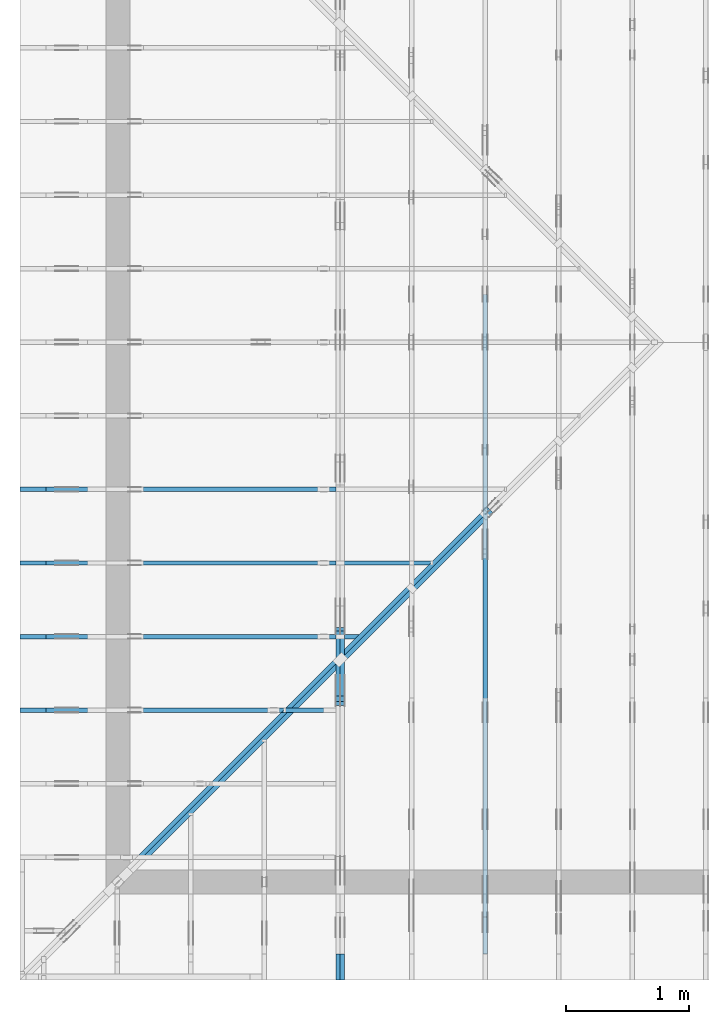
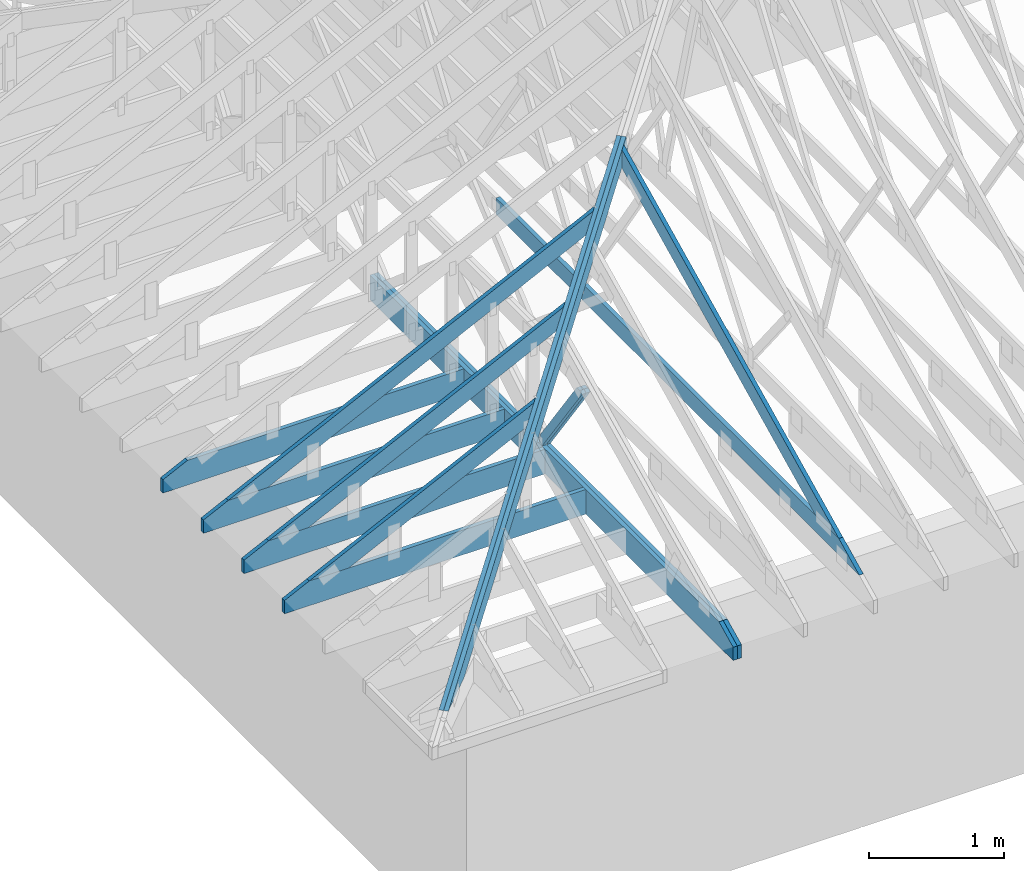
# One storey, part 3 of 159: 15 members, 7 elements without a shape of their own.
"""IFC2X3 building model written with IfcOpenShell, lengths in millimetres."""

from ifc_helpers import new_model, si_unit, frame, origin, origin_with_axes, origin_2d, place, context, project, spatial, faceted_brep, element, aggregate, save


model = new_model("IFC2X3")

# Units and contexts
model_context = context("Model", 3, precision=1e-05, world=origin())
plan_context = context("Plan", 2, precision=1e-05, world=origin_2d())
ifc_project = project(units=[si_unit("LENGTHUNIT", "METRE", prefix="MILLI"), si_unit("AREAUNIT", "SQUARE_METRE"), si_unit("VOLUMEUNIT", "CUBIC_METRE"), si_unit("SOLIDANGLEUNIT", "STERADIAN"), si_unit("PLANEANGLEUNIT", "RADIAN"), si_unit("MASSUNIT", "GRAM"), si_unit("TIMEUNIT", "SECOND"), si_unit("THERMODYNAMICTEMPERATUREUNIT", "DEGREE_CELSIUS"), si_unit("LUMINOUSINTENSITYUNIT", "LUMEN")], contexts=[model_context, plan_context])

# Site, building, storey
site_placement = place(None, origin_with_axes())
site = spatial("IfcSite", under=ifc_project, at=site_placement, CompositionType="ELEMENT")
building_placement = place(site_placement, origin_with_axes())
building = spatial("IfcBuilding", under=site, at=building_placement, Name="Plan 1", CompositionType="ELEMENT")
storey_placement = place(building_placement, origin_with_axes())
storey = spatial("IfcBuildingStorey", under=building, at=storey_placement, Name="Etasje 1", CompositionType="ELEMENT", Elevation=0.0)

# Assembly, member
assembly_1_placement = place(storey_placement, frame((-700.000000000007, 3282.0074014212605, 1.1021457184401395e-15), z_axis=(0.0, -1.0, 6.123031769111886e-17), x_axis=(1.0, 0.0, 0.0)))
assembly_1 = element("IfcElementAssembly", 1, at=assembly_1_placement, inside=storey, Name="S3 (19)", AssemblyPlace="FACTORY", PredefinedType="TRUSS")
member_1_placement = place(assembly_1_placement, frame((2575.022261404757, 223.00000000093104, -36.0), z_axis=(0.0, 0.0, 1.0), x_axis=(-1.0, 1.2246063538223773e-16, 0.0)))
member_1 = element("IfcMember", 2, at=member_1_placement, Name="S3-U11", context=model_context, shape_type="Brep", body=[
    faceted_brep([(2575.022261404768, 223.00000000093135, 36.0), (4.460788204596611e-05, 223.00000000093135, 36.0), (4.460788204596611e-05, 9.310383575211745e-10, 36.0), (2363.8409717319055, 9.310383575211745e-10, 36.0), (2575.022261404761, 103.00000000093135, 36.0), (4.460788204596611e-05, 223.00000000093135, 5.462709578404924e-21), (2575.022261404768, 223.00000000093135, 3.1533886225503453e-13), (2575.022261404761, 103.00000000093135, 3.1533886225503367e-13), (2363.8409717319055, 9.310383575211745e-10, 2.894774673408554e-13), (4.460788204596611e-05, 9.310383575211745e-10, 5.462709578404924e-21), (1.1401554882727804e-25, 9.310383575211745e-10, -6.981208276421509e-42), (2.2042914369942947e-15, 9.310383575211745e-10, 36.0), (2.9513013127233304e-14, 223.00000000093104, 36.0), (2.730872169035303e-14, 223.00000000093104, -1.6721217048386645e-30), (2363.8409657211496, 5.20089044280899e-13, -3.184521740898993e-29), (2363.8409657211496, 5.222933357177793e-13, 36.0), (8.67712118026388e-28, 9.310405618126114e-10, 36.0), (0.0, 9.310383575211745e-10, 0.0), (2575.022261404761, 103.00000000064097, -3.7865323450608567e-29), (2575.022261404761, 103.00000000064097, 36.0), (2363.8409657211496, 5.684341886080801e-13, 36.0), (2363.8409657211496, 5.684341886080801e-13, -2.524354896707238e-29), (2575.022261404755, 223.00000000093135, -7.825500179792437e-28), (2575.022261404755, 223.00000000093135, 36.0), (2575.022261404755, 103.00000000064031, 36.0), (2575.022261404755, 103.00000000064031, -3.534096855390133e-28), (0.0, 223.00000000093104, 0.0), (0.0, 223.00000000093104, 36.0), (2575.022261404768, 223.00000000093144, 36.0), (2575.022261404768, 223.00000000093146, 6.310887241768095e-30)], [[[0, 1, 2, 3, 4]], [[5, 6, 7, 8, 9]], [[10, 11, 12, 13]], [[14, 15, 16, 17]], [[18, 19, 20, 21]], [[22, 23, 24, 25]], [[26, 27, 28, 29]]]),
])
aggregate(assembly_1, [member_1])

# Assembly, members
assembly_2_placement = place(storey_placement, frame((-700.000000000007, 1482.0074014212605, 1.1021457184401395e-15), z_axis=(0.0, -1.0, 6.123031769111886e-17), x_axis=(1.0, 0.0, 0.0)))
assembly_2 = element("IfcElementAssembly", 3, at=assembly_2_placement, inside=storey, Name="S6 (18)", AssemblyPlace="FACTORY", PredefinedType="TRUSS")
member_2_placement = place(assembly_2_placement, frame((276.06014447168195, 89.97844131515879, -36.00000021758847), z_axis=(0.0, 0.0, 1.0), x_axis=(0.898794046299167, 0.4383711467890774, 0.0)))
member_2 = element("IfcMember", 4, at=member_2_placement, Name="S6-O53", context=model_context, shape_type="Brep", body=[
    faceted_brep([(2176.153074155777, 148.00000083082682, 2.253329398627102e-06), (2136.0994071584437, 147.9999951378918, 35.99999718737888), (2063.914983207369, 3.211827106497367e-07, 36.00000021758876), (2103.9686531498965, -1.7053025658242404e-13, 0.0), (4.108039797756646e-05, 148.00000032047896, 2.175884716848486e-07), (4.108039797756646e-05, 148.00000032047873, 36.00000021758847), (2136.099406314773, 148.0000003204786, 36.00000021758847), (2176.1530752906033, 148.00000032047882, 2.175884716848486e-07), (303.44505876091887, 3.208057108849971e-07, 2.1758847168484863e-07), (303.44505876091887, 3.208057108849971e-07, 36.00000021758847), (8.70477876020459e-05, 148.00000186174597, 36.00000021758847), (8.70477876020459e-05, 148.00000186174597, 2.1758847168484863e-07), (2103.9686530644794, 3.2119091710588915e-07, 2.175884716848486e-07), (2063.9149840886494, 3.211910385781581e-07, 36.00000021758847), (303.44509349416694, 3.211913619605502e-07, 36.00000021758847), (303.44509349416694, 3.2119124784577786e-07, 2.175884716848486e-07), (2136.099408561373, 148.00000032118282, 36.00000021758847), (0.00018828549389127147, 148.00000032118282, 36.00000021758847), (303.445012504244, 3.208056966741424e-07, 36.00000021758847), (2063.914983207369, 3.208056966741424e-07, 36.00000021758847), (0.0, 148.0000003209543, 2.1758847168484863e-07), (2176.153076171875, 148.0000003209543, 2.17588738177937e-07), (2103.968650817871, 3.2046978049038444e-07, 2.1758872933818643e-07), (303.4450683593751, 3.2046978049038444e-07, 2.1758850884492452e-07)], [[[0, 1, 2, 3]], [[4, 5, 6, 7]], [[8, 9, 10, 11]], [[12, 13, 14, 15]], [[16, 17, 18, 19]], [[20, 21, 22, 23]]]),
])
member_3_placement = place(assembly_2_placement, frame((2575.022261404756, 223.00000000093104, -36.0), z_axis=(0.0, 0.0, 1.0), x_axis=(-1.0, 1.2246063538223773e-16, 0.0)))
member_3 = element("IfcMember", 5, at=member_3_placement, Name="S6-U11", context=model_context, shape_type="Brep", body=[
    faceted_brep([(2575.022261404767, 223.00000000093135, 36.0), (4.4607881136471406e-05, 223.00000000093135, 36.0), (4.4607881136471406e-05, 9.310383575211745e-10, 36.0), (2363.8409717319046, 9.310383575211745e-10, 36.0), (2575.0222614047602, 103.00000000093135, 36.0), (4.4607881136471406e-05, 223.00000000093135, 5.462709467027625e-21), (2575.022261404767, 223.00000000093135, 3.1533886225503443e-13), (2575.0222614047602, 103.00000000093135, 3.1533886225503357e-13), (2363.8409717319046, 9.310383575211745e-10, 2.8947746734085526e-13), (4.4607881136471406e-05, 9.310383575211745e-10, 5.462709467027625e-21), (1.1401554882727804e-25, 9.310383575211745e-10, -6.981208276421509e-42), (2.2042914369942947e-15, 9.310383575211745e-10, 36.0), (2.9513013127233304e-14, 223.00000000093104, 36.0), (2.730872169035303e-14, 223.00000000093104, -1.6721217048386645e-30), (2363.8409657211487, 5.200890442812092e-13, -3.184521740901289e-29), (2363.8409657211487, 5.222933357180895e-13, 36.0), (8.67712118026388e-28, 9.310405618126114e-10, 36.0), (0.0, 9.310383575211745e-10, 0.0), (2575.0222614047602, 103.00000000064097, -5.048709793414476e-29), (2575.0222614047602, 103.00000000064097, 36.0), (2363.840965721148, 4.547473508864641e-13, 36.0), (2363.840965721148, 4.547473508864641e-13, -3.7865323450608567e-29), (2575.0222614047543, 223.00000000093135, -7.825500179792437e-28), (2575.0222614047543, 223.00000000093135, 36.0), (2575.0222614047543, 103.00000000064031, 36.0), (2575.0222614047543, 103.00000000064031, -3.534096855390133e-28), (0.0, 223.00000000093104, 0.0), (0.0, 223.00000000093104, 36.0), (2575.022261404767, 223.00000000093144, 36.0), (2575.022261404767, 223.00000000093146, 6.310887241768095e-30)], [[[0, 1, 2, 3, 4]], [[5, 6, 7, 8, 9]], [[10, 11, 12, 13]], [[14, 15, 16, 17]], [[18, 19, 20, 21]], [[22, 23, 24, 25]], [[26, 27, 28, 29]]]),
])
aggregate(assembly_2, [member_2, member_3])

assembly_3_placement = place(storey_placement, frame((-700.000000000007, 2682.0074014212605, 1.1021457184401395e-15), z_axis=(0.0, -1.0, 6.123031769111886e-17), x_axis=(1.0, 0.0, 0.0)))
assembly_3 = element("IfcElementAssembly", 6, at=assembly_3_placement, inside=storey, Name="S4 (17)", AssemblyPlace="FACTORY", PredefinedType="TRUSS")
member_4_placement = place(assembly_3_placement, frame((276.0601571593204, 89.97844750412699, -36.00000021758819), z_axis=(0.0, 0.0, 1.0), x_axis=(0.898794046299167, 0.4383711467890774, 0.0)))
member_4 = element("IfcMember", 7, at=member_4_placement, Name="S4-O30", context=model_context, shape_type="Brep", body=[
    faceted_brep([(3511.2753886097103, 148.0000008308283, 2.2533279206982115e-06), (3471.221721612377, 147.9999951378934, 35.999997187376266), (3399.0372976613044, 3.211828243365744e-07, 36.00000021758865), (3439.0909676038323, -2.2737367544323206e-13, 4.547473508864641e-13), (4.108039826178356e-05, 148.00000031881802, 2.1758818036232694e-07), (4.108039826178356e-05, 148.00000031881802, 36.00000021758818), (3471.221720767898, 148.0000003188178, 36.00000021758818), (3511.2753897437283, 148.0000003188178, 2.1758818036232694e-07), (303.4450446442798, 3.200922549240204e-07, 2.1758818036232697e-07), (303.4450446442798, 3.200922549240204e-07, 36.00000021758818), (7.293114850170923e-05, 148.0000018610325, 36.00000021758818), (7.293114850170923e-05, 148.0000018610325, 2.1758818036232697e-07), (3439.090967518421, 3.2119633011529756e-07, 2.1758818036232697e-07), (3399.037298542591, 3.2119633967708563e-07, 36.00000021758818), (303.44497142467134, 3.2119690830939053e-07, 36.00000021758818), (303.44497142467134, 3.211969061050991e-07, 2.1758818036232697e-07), (3471.221723015308, 148.00000032118305, 36.00000021758818), (0.0001882863040805205, 148.00000032118305, 36.00000021758818), (303.44501250505397, 3.2009239703256753e-07, 36.00000021758818), (3399.037297661304, 3.2009239703256753e-07, 36.00000021758818), (0.0, 148.00000032024116, 2.1758818036232697e-07), (3511.2753906250005, 148.00000032024116, 2.175886103553423e-07), (3439.090965270997, 3.1880153983365744e-07, 2.1758860151559172e-07), (303.4450683593755, 3.1880153983365744e-07, 2.1758821752240285e-07)], [[[0, 1, 2, 3]], [[4, 5, 6, 7]], [[8, 9, 10, 11]], [[12, 13, 14, 15]], [[16, 17, 18, 19]], [[20, 21, 22, 23]]]),
])
member_5_placement = place(assembly_3_placement, frame((2575.022261404757, 223.00000000093104, -36.0), z_axis=(0.0, 0.0, 1.0), x_axis=(-1.0, 1.2246063538223773e-16, 0.0)))
member_5 = element("IfcMember", 8, at=member_5_placement, Name="S4-U11", context=model_context, shape_type="Brep", body=[
    faceted_brep([(2575.022261404768, 223.00000000093135, 36.0), (4.460788204596611e-05, 223.00000000093135, 36.0), (4.460788204596611e-05, 9.310383575211745e-10, 36.0), (2363.8409717319055, 9.310383575211745e-10, 36.0), (2575.022261404761, 103.00000000093135, 36.0), (4.460788204596611e-05, 223.00000000093135, 5.462709578404924e-21), (2575.022261404768, 223.00000000093135, 3.1533886225503453e-13), (2575.022261404761, 103.00000000093135, 3.1533886225503367e-13), (2363.8409717319055, 9.310383575211745e-10, 2.894774673408554e-13), (4.460788204596611e-05, 9.310383575211745e-10, 5.462709578404924e-21), (1.1401554882727804e-25, 9.310383575211745e-10, -6.981208276421509e-42), (2.2042914369942947e-15, 9.310383575211745e-10, 36.0), (2.9513013127233304e-14, 223.00000000093104, 36.0), (2.730872169035303e-14, 223.00000000093104, -1.6721217048386645e-30), (2363.8409657211496, 5.20089044280899e-13, -3.184521740898993e-29), (2363.8409657211496, 5.222933357177793e-13, 36.0), (8.67712118026388e-28, 9.310405618126114e-10, 36.0), (0.0, 9.310383575211745e-10, 0.0), (2575.022261404761, 103.00000000064097, -3.7865323450608567e-29), (2575.022261404761, 103.00000000064097, 36.0), (2363.8409657211496, 5.684341886080801e-13, 36.0), (2363.8409657211496, 5.684341886080801e-13, -2.524354896707238e-29), (2575.022261404755, 223.00000000093135, -7.825500179792437e-28), (2575.022261404755, 223.00000000093135, 36.0), (2575.022261404755, 103.00000000064031, 36.0), (2575.022261404755, 103.00000000064031, -3.534096855390133e-28), (0.0, 223.00000000093104, 0.0), (0.0, 223.00000000093104, 36.0), (2575.022261404768, 223.00000000093144, 36.0), (2575.022261404768, 223.00000000093146, 6.310887241768095e-30)], [[[0, 1, 2, 3, 4]], [[5, 6, 7, 8, 9]], [[10, 11, 12, 13]], [[14, 15, 16, 17]], [[18, 19, 20, 21]], [[22, 23, 24, 25]], [[26, 27, 28, 29]]]),
])
aggregate(assembly_3, [member_4, member_5])

assembly_4_placement = place(storey_placement, frame((-700.000000000007, 2082.0074014212605, 1.1021457184401395e-15), z_axis=(0.0, -1.0, 6.123031769111886e-17), x_axis=(1.0, 0.0, 0.0)))
assembly_4 = element("IfcElementAssembly", 9, at=assembly_4_placement, inside=storey, Name="S5 (10)", AssemblyPlace="FACTORY", PredefinedType="TRUSS")
member_6_placement = place(assembly_4_placement, frame((276.0602103296791, 89.97847343571982, -36.00000021758215), z_axis=(0.0, 0.0, 1.0), x_axis=(0.898794046299167, 0.4383711467890774, 0.0)))
member_6 = element("IfcMember", 10, at=member_6_placement, Name="S5-O40", context=model_context, shape_type="Brep", body=[
    faceted_brep([(2843.714165167188, 148.00000083081602, 2.253328602819238e-06), (2803.6604981698492, 147.9999951378901, 35.99999718737149), (2731.476074218751, 3.2119237403094303e-07, 36.00000021758274), (2771.529744161284, -1.1368683772161603e-13, 6.821210263296962e-13), (9.693552647149772e-05, 148.00000032048274, 2.1758214785450034e-07), (9.693552647149772e-05, 148.00000032048297, 36.000000217582155), (2803.660497326152, 148.00000032048342, 36.000000217582155), (2843.714166301982, 148.0000003204832, 2.1758214785450034e-07), (303.4449854874161, 3.2128232874129026e-07, 2.1758214785450036e-07), (303.4449854874161, 3.2128232874129026e-07, 36.00000021758215), (1.3774284767009704e-05, 148.0000018622226, 36.00000021758215), (1.3774284767009704e-05, 148.0000018622226, 2.1758214785450036e-07), (2771.5297440758577, 3.2119052863899196e-07, 2.1758214785450036e-07), (2731.4760751000276, 3.2119053820078e-07, 36.00000021758215), (303.4450272789825, 3.2119098420811727e-07, 36.00000021758215), (303.4450272789825, 3.2119098200382583e-07, 2.1758214785450036e-07), (2803.660499572754, 148.00000032119237, 36.00000021758215), (0.0, 148.00000032119237, 36.00000021758215), (303.4450683593748, 3.2128241400641855e-07, 36.00000021758215), (2731.4760742187505, 3.2128241400641855e-07, 36.00000021758215), (5.585512843708784e-05, 148.00000032143058, 2.175821478545072e-07), (2843.7141671832537, 148.00000032143058, 2.1758249609754412e-07), (2771.52974182925, 3.2046932574303355e-07, 2.1758248725779354e-07), (303.44488007387827, 3.2046932574303355e-07, 2.1758218501455317e-07)], [[[0, 1, 2, 3]], [[4, 5, 6, 7]], [[8, 9, 10, 11]], [[12, 13, 14, 15]], [[16, 17, 18, 19]], [[20, 21, 22, 23]]]),
])
member_7_placement = place(assembly_4_placement, frame((2575.0222614047557, 223.00000000093104, -36.0), z_axis=(0.0, 0.0, 1.0), x_axis=(-1.0, 1.2246063538223773e-16, 0.0)))
member_7 = element("IfcMember", 11, at=member_7_placement, Name="S5-U11", context=model_context, shape_type="Brep", body=[
    faceted_brep([(2575.0222614047666, 223.00000000093135, 36.0), (4.4607880681724055e-05, 223.00000000093135, 36.0), (4.4607880681724055e-05, 9.310383575211745e-10, 36.0), (2363.840971731904, 9.310383575211745e-10, 36.0), (2575.02226140476, 103.00000000093135, 36.0), (4.4607880681724055e-05, 223.00000000093135, 5.4627094113389755e-21), (2575.0222614047666, 223.00000000093135, 3.153388622550344e-13), (2575.02226140476, 103.00000000093135, 3.153388622550335e-13), (2363.840971731904, 9.310383575211745e-10, 2.894774673408552e-13), (4.4607880681724055e-05, 9.310383575211745e-10, 5.4627094113389755e-21), (1.1401554882727804e-25, 9.310383575211745e-10, -6.981208276421509e-42), (2.2042914369942947e-15, 9.310383575211745e-10, 36.0), (2.9513013127233304e-14, 223.00000000093104, 36.0), (2.730872169035303e-14, 223.00000000093104, -1.6721217048386645e-30), (2363.840965721148, 5.20089044281416e-13, -3.184521740902437e-29), (2363.840965721148, 5.222933357182963e-13, 36.0), (8.67712118026388e-28, 9.310405618126114e-10, 36.0), (0.0, 9.310383575211745e-10, 0.0), (2575.022261404759, 103.00000000064074, -5.048709793414476e-29), (2575.022261404759, 103.00000000064074, 36.0), (2363.840965721148, 6.821210263296962e-13, 36.0), (2363.840965721148, 6.821210263296962e-13, -3.7865323450608567e-29), (2575.022261404754, 223.00000000093135, -7.825500179792437e-28), (2575.022261404754, 223.00000000093135, 36.0), (2575.022261404754, 103.00000000064031, 36.0), (2575.022261404754, 103.00000000064031, -3.534096855390133e-28), (0.0, 223.00000000093104, 0.0), (0.0, 223.00000000093104, 36.0), (2575.0222614047666, 223.00000000093144, 36.0), (2575.0222614047666, 223.00000000093146, 6.310887241768095e-30)], [[[0, 1, 2, 3, 4]], [[5, 6, 7, 8, 9]], [[10, 11, 12, 13]], [[14, 15, 16, 17]], [[18, 19, 20, 21]], [[22, 23, 24, 25]], [[26, 27, 28, 29]]]),
])
aggregate(assembly_4, [member_6, member_7])

assembly_5_placement = place(storey_placement, frame((-674.5441558772914, -725.4547742521996, 2.204291436880279e-15), z_axis=(0.7071067811865475, -0.7071067811865476, 6.123031769111886e-17), x_axis=(0.7071067811865476, 0.7071067811865475, 0.0)))
assembly_5 = element("IfcElementAssembly", 12, at=assembly_5_placement, inside=storey, Name="GR1 (8)", AssemblyPlace="FACTORY", PredefinedType="TRUSS")
member_8_placement = place(assembly_5_placement, frame((382.90850618663825, 83.08701368323861, -36.00000195234117), z_axis=(0.0, 0.0, 1.0), x_axis=(0.9453579955214152, 0.32603413978252627, 0.0)))
member_8 = element("IfcMember", 13, at=member_8_placement, Name="GR1-O2", context=model_context, shape_type="Brep", body=[
    faceted_brep([(9.094947017729282e-13, 148.00000315181347, 1.952341179389805e-06), (9.094947017729282e-13, 148.00000315181347, 36.00000195234118), (5380.000000000001, 148.00000315181313, 36.00000195234118), (5380.000000000001, 148.00000315181313, 1.952341179389805e-06), (429.13598996492084, 3.151003625134763e-06, 1.952341179389805e-06), (429.13598996492084, 3.151003625134763e-06, 36.00000195234118), (6.069707794154056e-06, 148.00000105849915, 36.00000195234118), (6.069707794154056e-06, 148.00000105849915, 1.952341179389805e-06), (5379.999999999999, 3.1509182713895772e-06, 1.952341179389805e-06), (5379.999999999999, 3.1509182735938687e-06, 36.00000195234118), (429.1362304687506, 3.150919183022753e-06, 36.00000195234118), (429.1362304687506, 3.1509191808184616e-06, 1.952341179389805e-06), (5380.0, 148.00000277524896, 1.8783536717137395e-06), (5379.999999999999, 148.00000277524896, 36.00000195234118), (5379.999999999999, 0.0, 36.00000255341424), (5380.0, 0.0, 0.0), (5379.999999999999, 148.00000315091938, 36.00000195234118), (4.547473508864641e-13, 148.00000315091938, 36.00000195234118), (429.1362304687506, 3.151003227230831e-06, 36.00000195234118), (5379.999999999999, 3.151003227230831e-06, 36.00000195234118), (0.0, 148.0000031518136, 1.952341179389805e-06), (5379.999999999999, 148.0000031518136, 1.9523418382280232e-06), (5380.0, 3.150919837935362e-06, 1.9523418382280232e-06), (429.1362304687497, 3.150919837935362e-06, 1.9523412319421e-06)], [[[0, 1, 2, 3]], [[4, 5, 6, 7]], [[8, 9, 10, 11]], [[12, 13, 14, 15]], [[16, 17, 18, 19]], [[20, 21, 22, 23]]]),
])
member_9_placement = place(assembly_5_placement, frame((382.90850618663825, 83.08701368323861, -72.00000195234118), z_axis=(0.0, 0.0, 1.0), x_axis=(0.9453579955214152, 0.32603413978252627, 0.0)))
member_9 = element("IfcMember", 14, at=member_9_placement, Name="GR1-O2", context=model_context, shape_type="Brep", body=[
    faceted_brep([(9.094947017729282e-13, 148.00000315181347, 1.952341179389805e-06), (9.094947017729282e-13, 148.00000315181347, 36.00000195234118), (5380.000000000001, 148.00000315181313, 36.00000195234118), (5380.000000000001, 148.00000315181313, 1.952341179389805e-06), (429.13598996492084, 3.151003625134763e-06, 1.952341179389805e-06), (429.13598996492084, 3.151003625134763e-06, 36.00000195234118), (6.069707794154056e-06, 148.00000105849915, 36.00000195234118), (6.069707794154056e-06, 148.00000105849915, 1.952341179389805e-06), (5379.999999999999, 3.1509182713895772e-06, 1.952341179389805e-06), (5379.999999999999, 3.1509182735938687e-06, 36.00000195234118), (429.1362304687506, 3.150919183022753e-06, 36.00000195234118), (429.1362304687506, 3.1509191808184616e-06, 1.952341179389805e-06), (5380.0, 148.00000277524896, 1.8783536717137395e-06), (5379.999999999999, 148.00000277524896, 36.00000195234118), (5379.999999999999, 0.0, 36.00000255341424), (5380.0, 0.0, 0.0), (5379.999999999999, 148.00000315091938, 36.00000195234118), (4.547473508864641e-13, 148.00000315091938, 36.00000195234118), (429.1362304687506, 3.151003227230831e-06, 36.00000195234118), (5379.999999999999, 3.151003227230831e-06, 36.00000195234118), (0.0, 148.0000031518136, 1.952341179389805e-06), (5379.999999999999, 148.0000031518136, 1.9523418382280232e-06), (5380.0, 3.150919837935362e-06, 1.9523418382280232e-06), (429.1362304687497, 3.150919837935362e-06, 1.9523412319421e-06)], [[[0, 1, 2, 3]], [[4, 5, 6, 7]], [[8, 9, 10, 11]], [[12, 13, 14, 15]], [[16, 17, 18, 19]], [[20, 21, 22, 23]]]),
])
aggregate(assembly_5, [member_8, member_9])

assembly_6_placement = place(storey_placement, frame((3075.02226140475, 9699.999999999993, 1.1021457184401395e-15), z_axis=(-1.0, 1.836909530733566e-16, 6.123031769111886e-17), x_axis=(-1.836909530733566e-16, -1.0, 0.0)))
assembly_6 = element("IfcElementAssembly", 15, at=assembly_6_placement, inside=storey, Name="V3 (4)", AssemblyPlace="FACTORY", PredefinedType="TRUSS")
member_10_placement = place(assembly_6_placement, frame((6575.009426493243, 1820.9069429410742, -36.00000021755148), z_axis=(0.0, 0.0, 1.0), x_axis=(0.8987940462991668, -0.4383711467890778, 0.0)))
member_10 = element("IfcMember", 16, at=member_10_placement, Name="V3-O28", context=model_context, shape_type="Brep", body=[
    faceted_brep([(112.23809389370763, 6.723852493450977e-06, 36.000003247708484), (40.05366994256022, 148.0000015405267, 36.00000021755145), (3.552713678800501e-14, 148.00000121932047, -2.842170943040401e-14), (72.1844239511469, 6.402646429037873e-06, 3.030156584316046e-06), (3307.487116487463, 1.5412372995212595e-06, 2.1755148083002496e-07), (3307.487116487463, 1.541237301725551e-06, 36.00000021755148), (112.23809304996121, 1.5412378886638894e-06, 36.00000021755148), (72.18442407413113, 1.5412378938170944e-06, 2.1755148083002496e-07), (8.545339369447902e-08, 148.00000154052213, 2.1755148083002496e-07), (40.05366906128347, 148.00000154052123, 36.000000217551474), (3610.9321289917016, 148.000001540521, 36.000000217551474), (3610.9321289917016, 148.0000015405219, 2.1755148083002496e-07), (3610.9321399749074, 148.00000154093823, 2.1755148083002496e-07), (3610.9321399749074, 148.00000154093823, 36.00000021755148), (3307.4871682617772, -2.0463630789890885e-12, 36.00000021755148), (3307.4871682617772, -2.0463630789890885e-12, 2.1755148083002496e-07), (3610.93208791131, 148.0000015409405, 36.00000021755148), (40.05366994256019, 148.0000015409405, 36.00000021755148), (112.238095296565, 1.5405266822199337e-06, 36.00000021755148), (3307.48726369256, 1.5405266822199337e-06, 36.00000021755148), (1.1068657840951346e-05, 148.00000154052213, 2.175514808300263e-07), (3610.932139974907, 148.00000154052213, 2.1755192302706913e-07), (3307.4871631682663, 1.5409405023092404e-06, 2.1755188586700447e-07), (72.18433724053193, 1.5409405023092404e-06, 2.1755148966976477e-07)], [[[0, 1, 2, 3]], [[4, 5, 6, 7]], [[8, 9, 10, 11]], [[12, 13, 14, 15]], [[16, 17, 18, 19]], [[20, 21, 22, 23]]]),
])
member_11_placement = place(assembly_6_placement, frame((10188.817634446546, 370.99999999999994, -36.0), z_axis=(0.0, 0.0, 1.0), x_axis=(-1.0, 1.2246063538223773e-16, 0.0)))
member_11 = element("IfcMember", 17, at=member_11_placement, Name="V3-U32", context=model_context, shape_type="Brep", body=[
    faceted_brep([(5379.999763352796, 148.0000000000006, 36.0), (0.00025163404643535614, 148.0000000000006, 36.0), (303.44458757154644, 0.0, 36.0), (5379.999763352796, 0.0, 36.0), (0.00025163404643535614, 148.0000000000006, 3.0815265210277225e-20), (5379.999763352796, 148.0000000000006, 6.588381893764721e-13), (5379.999763352796, 0.0, 6.588381893764721e-13), (303.44458757154644, 0.0, 3.7160016997312653e-14), (303.4449685551226, 1.4210854715202004e-14, 0.0), (303.4449685551226, 1.4210854715202004e-14, 36.0), (-1.4210854715202004e-14, 147.99999999999994, 36.0), (-1.4210854715202004e-14, 147.99999999999994, 0.0), (5379.999999999999, -9.984505684284977e-13, 7.157706729024497e-29), (5379.999999999999, -9.962462769916175e-13, 36.0), (303.4449685551226, -6.372904493616443e-14, 36.0), (303.4449685551226, -6.593333637304471e-14, 4.03711913255693e-30), (5379.999999999999, 148.00000000000014, 0.0), (5379.999999999999, 148.00000000000014, 36.0), (5379.999999999999, 1.7053025658242404e-13, 36.0), (5379.999999999999, 1.7053025658242404e-13, 0.0), (0.0, 147.99999999999994, 0.0), (0.0, 147.99999999999994, 36.0), (5379.999999999999, 147.9999999999996, 36.0), (5379.999999999999, 147.9999999999996, -3.3132158019282496e-29)], [[[0, 1, 2, 3]], [[4, 5, 6, 7]], [[8, 9, 10, 11]], [[12, 13, 14, 15]], [[16, 17, 18, 19]], [[20, 21, 22, 23]]]),
])
aggregate(assembly_6, [member_10, member_11])

assembly_7_placement = place(storey_placement, frame((1875.0222614047502, 9699.999999999993, 0.0), z_axis=(-1.0, 1.836909530733566e-16, 6.123031769111886e-17), x_axis=(-1.836909530733566e-16, -1.0, 0.0)))
assembly_7 = element("IfcElementAssembly", 18, at=assembly_7_placement, inside=storey, Name="V1 (2)", AssemblyPlace="FACTORY", PredefinedType="TRUSS")
member_12_placement = place(assembly_7_placement, frame((10399.9990234375, 222.99999999999997, -36.0), z_axis=(0.0, 0.0, 1.0), x_axis=(-1.0, 1.2246063538223773e-16, 0.0)))
member_12 = element("IfcMember", 19, at=member_12_placement, Name="V1-U2", context=model_context, shape_type="Brep", body=[
    faceted_brep([(5380.0, 223.00000000000063, 36.0), (0.0, 223.00000000000063, 36.0), (0.0, 102.99998474121091, 36.0), (211.181640625, 0.0, 36.0), (5380.0, 0.0, 36.0), (0.0, 223.00000000000063, 0.0), (5380.0, 223.00000000000063, 6.58838218356439e-13), (5380.0, 0.0, 6.58838218356439e-13), (211.181640625, 0.0, 2.5861437892000887e-14), (0.0, 102.99998474121091, 0.0), (0.00012207031978857106, 102.99998597070223, -7.723249910891245e-31), (0.00012207031979077535, 102.99998597070223, 36.0), (0.00012207031980547063, 222.99999999999997, 36.0), (0.00012207031980326634, 222.99999999999997, -1.67212096573961e-30), (211.1813889909535, -8.526512829121202e-14, 7.099748146989106e-30), (211.1813889909535, -8.526512829121202e-14, 36.0), (0.00012207031977595761, 102.99998597070223, 36.0), (0.00012207031977595761, 102.99998597070223, 7.888609052210118e-31), (5380.00012207032, -1.0126429715252426e-12, 9.855012710688366e-29), (5380.00012207032, -1.0104386800883623e-12, 36.0), (211.18138899095356, -6.097344074559397e-14, 36.0), (211.18138899095356, -6.317773218247425e-14, 3.8683926125373226e-30), (5380.00012207032, 223.00000000000063, 0.0), (5380.00012207032, 223.00000000000063, 36.0), (5380.00012207032, 5.968558980384842e-13, 36.0), (5380.00012207032, 5.968558980384842e-13, 0.0), (0.00012207031977595761, 222.99999999999997, 0.0), (0.00012207031977595761, 222.99999999999997, 36.0), (5380.00012207032, 223.00000000000082, 36.0), (5380.00012207032, 223.00000000000082, 1.4199496293978212e-29)], [[[0, 1, 2, 3, 4]], [[5, 6, 7, 8, 9]], [[10, 11, 12, 13]], [[14, 15, 16, 17]], [[18, 19, 20, 21]], [[22, 23, 24, 25]], [[26, 27, 28, 29]]]),
])
member_13_placement = place(assembly_7_placement, frame((10399.9990234375, 222.99999999999997, -72.0), z_axis=(0.0, 0.0, 1.0), x_axis=(-1.0, 1.2246063538223773e-16, 0.0)))
member_13 = element("IfcMember", 20, at=member_13_placement, Name="V1-U2", context=model_context, shape_type="Brep", body=[
    faceted_brep([(5380.0, 223.00000000000063, 36.0), (0.0, 223.00000000000063, 36.0), (0.0, 102.99998474121091, 36.0), (211.181640625, 0.0, 36.0), (5380.0, 0.0, 36.0), (0.0, 223.00000000000063, 0.0), (5380.0, 223.00000000000063, 6.58838218356439e-13), (5380.0, 0.0, 6.58838218356439e-13), (211.181640625, 0.0, 2.5861437892000887e-14), (0.0, 102.99998474121091, 0.0), (0.00012207031978857106, 102.99998597070223, -7.723249910891245e-31), (0.00012207031979077535, 102.99998597070223, 36.0), (0.00012207031980547063, 222.99999999999997, 36.0), (0.00012207031980326634, 222.99999999999997, -1.67212096573961e-30), (211.1813889909535, -8.526512829121202e-14, 7.099748146989106e-30), (211.1813889909535, -8.526512829121202e-14, 36.0), (0.00012207031977595761, 102.99998597070223, 36.0), (0.00012207031977595761, 102.99998597070223, 7.888609052210118e-31), (5380.00012207032, -1.0126429715252426e-12, 9.855012710688366e-29), (5380.00012207032, -1.0104386800883623e-12, 36.0), (211.18138899095356, -6.097344074559397e-14, 36.0), (211.18138899095356, -6.317773218247425e-14, 3.8683926125373226e-30), (5380.00012207032, 223.00000000000063, 0.0), (5380.00012207032, 223.00000000000063, 36.0), (5380.00012207032, 5.968558980384842e-13, 36.0), (5380.00012207032, 5.968558980384842e-13, 0.0), (0.00012207031977595761, 222.99999999999997, 0.0), (0.00012207031977595761, 222.99999999999997, 36.0), (5380.00012207032, 223.00000000000082, 36.0), (5380.00012207032, 223.00000000000082, 1.4199496293978212e-29)], [[[0, 1, 2, 3, 4]], [[5, 6, 7, 8, 9]], [[10, 11, 12, 13]], [[14, 15, 16, 17]], [[18, 19, 20, 21]], [[22, 23, 24, 25]], [[26, 27, 28, 29]]]),
])
member_14_placement = place(assembly_7_placement, frame((8102.384720547016, 1089.5801956409541, -36.0), z_axis=(0.0, 0.0, 1.0), x_axis=(-0.5829248698635331, -0.8125260587172469, 0.0)))
member_14 = element("IfcMember", 21, at=member_14_placement, Name="V1-D50", context=model_context, shape_type="Brep", body=[
    faceted_brep([(1014.1541601321987, 72.99999567182749, 36.0), (0.0, 72.99999567182749, 36.0), (6.210413284990864, 36.50019404393879, 36.0), (32.396491423392945, 0.0, 36.0), (943.5186906107447, 0.0, 36.0), (1040.3399536393154, 36.50019404393879, 36.0), (0.0, 72.99999567182749, 0.0), (1014.1541601321987, 72.99999567182749, 1.2419396282532873e-13), (1040.3399536393154, 36.50019404393879, 1.274006917361983e-13), (943.5186906107447, 0.0, 1.1554389834720876e-13), (32.396491423392945, 0.0, 3.967294923863915e-15), (6.210413284990864, 36.50019404393879, 7.605311568662714e-16), (6.210564994748909, 36.50001031697229, -8.336332703061618e-31), (6.2105649947489106, 36.50001031697229, 36.0), (5.840196566353484e-06, 73.00001031435934, 36.0), (5.840196564577127e-06, 73.00001031435934, -1.7626639723520218e-30), (32.39650392344265, 1.0314359313312593e-05, -1.1638606939434147e-31), (32.39650392344265, 1.031435931508895e-05, 36.0), (6.2105649947489, 36.50001031697231, 36.0), (6.210564994748898, 36.50001031697231, -4.311807905996928e-31), (943.518747214719, 1.0314356724750023e-05, -8.458673219082068e-30), (943.518747214719, 1.0314356726954315e-05, 36.0), (32.39650392344265, 1.0314359322036572e-05, 36.0), (32.39650392344265, 1.031435931983228e-05, -2.904355958678349e-31), (1040.340088553823, 36.50001031435977, -2.524354896707238e-29), (1040.340088553823, 36.50001031435977, 36.0), (943.5187472147189, 1.0314356927665358e-05, 36.0), (943.5187472147189, 1.0314356927665358e-05, -2.208810534618833e-29), (1014.1541496270108, 73.00001031435744, -1.262177448353619e-29), (1014.1541496270108, 73.00001031435744, 36.0), (1040.3400885538229, 36.500010314359315, 36.0), (1040.3400885538229, 36.500010314359315, -6.310887241768095e-30), (5.840196536155418e-06, 73.00001031435932, 0.0), (5.840196536155418e-06, 73.00001031435932, 36.0), (1014.1541496270111, 73.00001031435745, 36.0), (1014.1541496270111, 73.00001031435745, -3.1554436208840472e-30)], [[[0, 1, 2, 3, 4, 5]], [[6, 7, 8, 9, 10, 11]], [[12, 13, 14, 15]], [[16, 17, 18, 19]], [[20, 21, 22, 23]], [[24, 25, 26, 27]], [[28, 29, 30, 31]], [[32, 33, 34, 35]]]),
])
member_15_placement = place(assembly_7_placement, frame((8102.384720547016, 1089.5801956409541, -72.0), z_axis=(0.0, 0.0, 1.0), x_axis=(-0.5829248698635331, -0.8125260587172469, 0.0)))
member_15 = element("IfcMember", 22, at=member_15_placement, Name="V1-D50", context=model_context, shape_type="Brep", body=[
    faceted_brep([(1014.1541601321987, 72.99999567182749, 36.0), (0.0, 72.99999567182749, 36.0), (6.210413284990864, 36.50019404393879, 36.0), (32.396491423392945, 0.0, 36.0), (943.5186906107447, 0.0, 36.0), (1040.3399536393154, 36.50019404393879, 36.0), (0.0, 72.99999567182749, 0.0), (1014.1541601321987, 72.99999567182749, 1.2419396282532873e-13), (1040.3399536393154, 36.50019404393879, 1.274006917361983e-13), (943.5186906107447, 0.0, 1.1554389834720876e-13), (32.396491423392945, 0.0, 3.967294923863915e-15), (6.210413284990864, 36.50019404393879, 7.605311568662714e-16), (6.210564994748909, 36.50001031697229, -8.336332703061618e-31), (6.2105649947489106, 36.50001031697229, 36.0), (5.840196566353484e-06, 73.00001031435934, 36.0), (5.840196564577127e-06, 73.00001031435934, -1.7626639723520218e-30), (32.39650392344265, 1.0314359313312593e-05, -1.1638606939434147e-31), (32.39650392344265, 1.031435931508895e-05, 36.0), (6.2105649947489, 36.50001031697231, 36.0), (6.210564994748898, 36.50001031697231, -4.311807905996928e-31), (943.518747214719, 1.0314356724750023e-05, -8.458673219082068e-30), (943.518747214719, 1.0314356726954315e-05, 36.0), (32.39650392344265, 1.0314359322036572e-05, 36.0), (32.39650392344265, 1.031435931983228e-05, -2.904355958678349e-31), (1040.340088553823, 36.50001031435977, -2.524354896707238e-29), (1040.340088553823, 36.50001031435977, 36.0), (943.5187472147189, 1.0314356927665358e-05, 36.0), (943.5187472147189, 1.0314356927665358e-05, -2.208810534618833e-29), (1014.1541496270108, 73.00001031435744, -1.262177448353619e-29), (1014.1541496270108, 73.00001031435744, 36.0), (1040.3400885538229, 36.500010314359315, 36.0), (1040.3400885538229, 36.500010314359315, -6.310887241768095e-30), (5.840196536155418e-06, 73.00001031435932, 0.0), (5.840196536155418e-06, 73.00001031435932, 36.0), (1014.1541496270111, 73.00001031435745, 36.0), (1014.1541496270111, 73.00001031435745, -3.1554436208840472e-30)], [[[0, 1, 2, 3, 4, 5]], [[6, 7, 8, 9, 10, 11]], [[12, 13, 14, 15]], [[16, 17, 18, 19]], [[20, 21, 22, 23]], [[24, 25, 26, 27]], [[28, 29, 30, 31]], [[32, 33, 34, 35]]]),
])
aggregate(assembly_7, [member_12, member_13, member_14, member_15])

save(model, "model.ifc")
